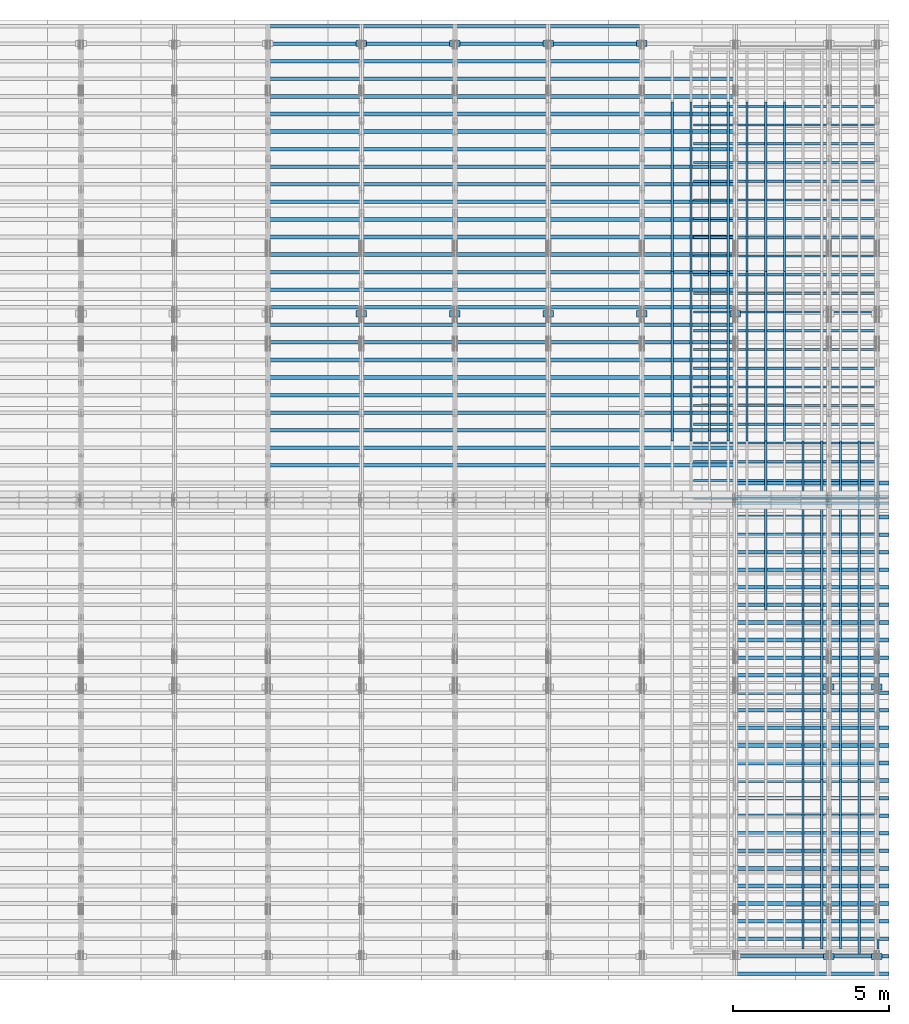
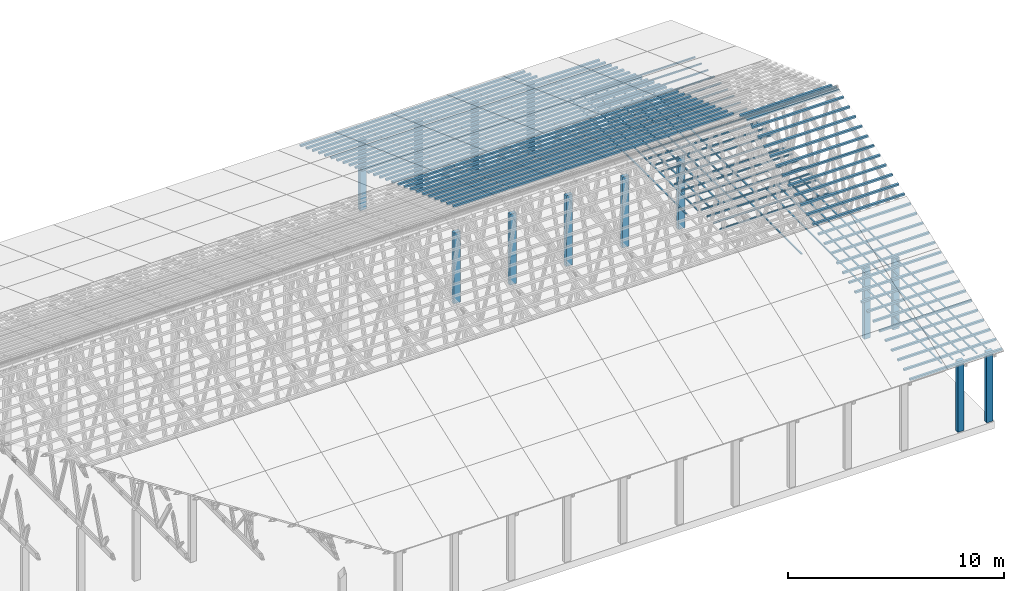
# One storey, part 4 of 189: 222 columns.
"""IFC2X3 building model written with IfcOpenShell, lengths in millimetres."""

from ifc_helpers import new_model, entity, si_unit, converted_unit, derived_unit, direction, frame, frame_2d, origin, origin_2d_with_axis, place, context, subcontext, project, spatial, rectangle, extrude, boolean, source, transform, mapped, material, type_object, type_shapes, element, save


model = new_model("IFC2X3")

# Units and contexts
model_context = context("Model", 3, precision=0.01, world=origin(), true_north=direction((6.12303176911189e-17, 1.0)))
body_context = subcontext(model_context, "Body", "Model", "MODEL_VIEW")
ifc_project = project(units=[si_unit("LENGTHUNIT", "METRE", prefix="MILLI"), si_unit("AREAUNIT", "SQUARE_METRE"), si_unit("VOLUMEUNIT", "CUBIC_METRE"), converted_unit("PLANEANGLEUNIT", "DEGREE", entity("IfcRatioMeasure", 0.0174532925199433), si_unit("PLANEANGLEUNIT", "RADIAN"), dimensions=[0, 0, 0, 0, 0, 0, 0]), si_unit("MASSUNIT", "GRAM", prefix="KILO"), derived_unit("MASSDENSITYUNIT", [(si_unit("MASSUNIT", "GRAM", prefix="KILO"), 1), (si_unit("LENGTHUNIT", "METRE"), -3)]), si_unit("TIMEUNIT", "SECOND"), si_unit("FREQUENCYUNIT", "HERTZ"), si_unit("THERMODYNAMICTEMPERATUREUNIT", "DEGREE_CELSIUS"), derived_unit("THERMALTRANSMITTANCEUNIT", [(si_unit("MASSUNIT", "GRAM", prefix="KILO"), 1), (si_unit("THERMODYNAMICTEMPERATUREUNIT", "KELVIN"), -1), (si_unit("TIMEUNIT", "SECOND"), -3)]), derived_unit("VOLUMETRICFLOWRATEUNIT", [(si_unit("LENGTHUNIT", "METRE"), 3), (si_unit("TIMEUNIT", "SECOND"), -1)]), si_unit("ELECTRICCURRENTUNIT", "AMPERE"), si_unit("ELECTRICVOLTAGEUNIT", "VOLT"), si_unit("POWERUNIT", "WATT"), si_unit("FORCEUNIT", "NEWTON"), si_unit("ILLUMINANCEUNIT", "LUX"), si_unit("LUMINOUSFLUXUNIT", "LUMEN"), si_unit("LUMINOUSINTENSITYUNIT", "CANDELA"), derived_unit("USERDEFINED", [(si_unit("MASSUNIT", "GRAM", prefix="KILO"), -1), (si_unit("LENGTHUNIT", "METRE"), -2), (si_unit("TIMEUNIT", "SECOND"), 3), (si_unit("LUMINOUSFLUXUNIT", "LUMEN"), 1)]), derived_unit("LINEARVELOCITYUNIT", [(si_unit("LENGTHUNIT", "METRE"), 1), (si_unit("TIMEUNIT", "SECOND"), -1)]), si_unit("PRESSUREUNIT", "PASCAL"), derived_unit("USERDEFINED", [(si_unit("LENGTHUNIT", "METRE"), -2), (si_unit("MASSUNIT", "GRAM", prefix="KILO"), 1), (si_unit("TIMEUNIT", "SECOND"), -2)])], contexts=[model_context])

# Site, building, storey
site_placement = place(None, origin())
site = spatial("IfcSite", under=ifc_project, at=site_placement, CompositionType="ELEMENT")
building_placement = place(site_placement, origin())
building = spatial("IfcBuilding", under=site, at=building_placement, CompositionType="ELEMENT")
storey_placement = place(building_placement, origin())
storey = spatial("IfcBuildingStorey", under=building, at=storey_placement, Name="Default", CompositionType="ELEMENT", Elevation=0.0)

# Columns
ifc_material_1 = material(Name="2")
column_type_1 = type_object("IfcColumnType", Name="100x70", PredefinedType="COLUMN")
shared_shape_1 = source(origin(), body_context, "Body", "CSG", [
    boolean("DIFFERENCE", extrude(rectangle(XDim=4925.15713546285, YDim=117.910672112436, at=frame_2d((0.0, -7.105427357601e-15), x_axis=(1.0, 0.0))), frame((2462.57856773143, 146.833369190677, -28.6286403914047)), (0.0, 0.0, 1.0), 99.9804977897746), extrude(rectangle(XDim=70.0000000018648, YDim=100.00000000027, at=frame_2d((3.5527136788005e-15, 3.5527136788005e-15), x_axis=(0.0, 1.0))), frame((4925.15713546285, 146.833369190677, 21.3616085034827), z_axis=(1.0, 0.0, 0.0), x_axis=(0.0, 0.939692620784201, -0.34202014333036)), (0.0, 0.0, -1.0), 4925.15713546285)),
])
type_shapes(column_type_1, [shared_shape_1])
for number, where, name in (
    (1, (45228.2629498526, 15149.3712807029, 5585.64342365955), "H_28_35_gradi:100x70"),
    (2, (45228.2629498526, 14712.1220107286, 5744.78914288479), "H_28_35_gradi:100x70"),
):
    element("IfcColumn", number, at=place(building_placement, frame(where)), inside=storey, type_object=column_type_1, material=ifc_material_1, Name=name, ObjectType="H_28_35_gradi:100x70", context=body_context, shape_type="MappedRepresentation", body=[
        mapped(shared_shape_1, transform((0.0, 0.0, 0.0), scale=1.0)),
    ])
column_type_2 = type_object("IfcColumnType", Name="100x70", PredefinedType="COLUMN")
shared_shape_2 = source(origin(), body_context, "Body", "CSG", [
    boolean("DIFFERENCE", extrude(rectangle(XDim=4925.15713546286, YDim=117.910672112436, at=frame_2d((0.0, 7.105427357601e-15), x_axis=(1.0, 0.0))), frame((2462.57856773143, -146.833369190677, -28.6286403914047)), (0.0, 0.0, 1.0), 99.9804977897746), extrude(rectangle(XDim=70.0000000018648, YDim=100.00000000027, at=frame_2d((3.5527136788005e-15, 3.5527136788005e-15), x_axis=(0.0, 1.0))), frame((0.0, -146.833369190677, 21.3616085034827), z_axis=(-1.0, 0.0, 0.0), x_axis=(0.0, -0.939692620784201, -0.34202014333036)), (0.0, 0.0, -1.0), 4925.15713546286)),
])
type_shapes(column_type_2, [shared_shape_2])
for number, where, name in (
    (3, (45228.2629498526, 255.239495233951, 455.341273776488), "H_28_35_gradi:100x70"),
    (4, (45228.2629498526, 819.05506770621, 660.553359769929), "H_28_35_gradi:100x70"),
    (5, (45228.2629498526, 1382.87064017775, 865.765445765329), "H_28_35_gradi:100x70"),
    (6, (45228.2629498526, 1946.6862126493, 1070.97753176073), "H_28_35_gradi:100x70"),
    (7, (45228.2629498526, 2510.50178512084, 1276.18961775613), "H_28_35_gradi:100x70"),
    (8, (45228.2629498526, 3074.31735759238, 1481.40170375153), "H_28_35_gradi:100x70"),
    (9, (45228.2629498526, 3638.13293006393, 1686.61378974693), "H_28_35_gradi:100x70"),
    (10, (45228.2629498526, 4201.94850253547, 1891.82587574233), "H_28_35_gradi:100x70"),
    (11, (45228.2629498526, 4765.76407500701, 2097.03796173773), "H_28_35_gradi:100x70"),
    (12, (45228.2629498526, 5329.57964747856, 2302.25004773314), "H_28_35_gradi:100x70"),
    (13, (45228.2629498526, 5893.3952199501, 2507.46213372854), "H_28_35_gradi:100x70"),
    (14, (45228.2629498526, 6457.21079242164, 2712.67421972394), "H_28_35_gradi:100x70"),
    (15, (45228.2629498526, 7021.02636489319, 2917.88630571934), "H_28_35_gradi:100x70"),
    (16, (45228.2629498526, 7584.84193736473, 3123.09839171474), "H_28_35_gradi:100x70"),
    (17, (45228.2629498526, 8148.65750983628, 3328.31047771014), "H_28_35_gradi:100x70"),
    (18, (45228.2629498526, 8712.47308230782, 3533.52256370554), "H_28_35_gradi:100x70"),
    (19, (45228.2629498526, 9276.28865477937, 3738.73464970094), "H_28_35_gradi:100x70"),
    (20, (45228.2629498526, 9840.10422725091, 3943.94673569634), "H_28_35_gradi:100x70"),
    (21, (45228.2629498526, 10403.9197997225, 4149.15882169174), "H_28_35_gradi:100x70"),
    (22, (45228.2629498526, 10967.735372194, 4354.37090768715), "H_28_35_gradi:100x70"),
    (23, (45228.2629498526, 11531.5509446655, 4559.58299368255), "H_28_35_gradi:100x70"),
    (24, (45228.2629498526, 12095.3665171371, 4764.79507967795), "H_28_35_gradi:100x70"),
    (25, (45228.2629498526, 12659.1820896086, 4970.00716567335), "H_28_35_gradi:100x70"),
    (26, (45228.2629498526, 13222.9976620802, 5175.21925166875), "H_28_35_gradi:100x70"),
    (27, (45228.2629498526, 13786.8132345517, 5380.43133766415), "H_28_35_gradi:100x70"),
    (28, (45228.2629498526, 14350.6288070233, 5585.64342365955), "H_28_35_gradi:100x70"),
    (29, (45228.2629498526, 14787.8780769975, 5744.78914288479), "H_28_35_gradi:100x70"),
    (30, (45228.2629498526, -308.576077237594, 250.129187781088), "H_28_35_gradi:100x70"),
):
    element("IfcColumn", number, at=place(storey_placement, frame(where)), inside=storey, type_object=column_type_2, material=ifc_material_1, Name=name, ObjectType="H_28_35_gradi:100x70", context=body_context, shape_type="MappedRepresentation", body=[
        mapped(shared_shape_2, transform((0.0, 0.0, 0.0), scale=1.0)),
    ])
column_type_3 = type_object("IfcColumnType", Name="100x70", PredefinedType="COLUMN")
shared_shape_3 = source(origin(), body_context, "Body", "CSG", [
    boolean("DIFFERENCE", extrude(rectangle(XDim=2998.26294985256, YDim=117.910672112436, at=frame_2d((0.0, -7.105427357601e-15), x_axis=(1.0, 0.0))), frame((1499.13147492628, 146.833369190677, -28.6286403914047)), (0.0, 0.0, 1.0), 99.9804977897746), extrude(rectangle(XDim=70.0000000018648, YDim=100.00000000027, at=frame_2d((3.5527136788005e-15, 3.5527136788005e-15), x_axis=(0.0, 1.0))), frame((2998.26294985256, 146.833369190677, 21.3616085034827), z_axis=(1.0, 0.0, 0.0), x_axis=(0.0, 0.939692620784201, -0.34202014333036)), (0.0, 0.0, -1.0), 2998.26294985256)),
])
type_shapes(column_type_3, [shared_shape_3])
for number, where, name in (
    (31, (42230.0, 28117.1294475484, 865.765445765329), "H_28_35_gradi:100x70"),
    (32, (42230.0, 27553.3138750769, 1070.97753176073), "H_28_35_gradi:100x70"),
    (33, (42230.0, 26989.4983026053, 1276.18961775613), "H_28_35_gradi:100x70"),
    (34, (42230.0, 26425.6827301338, 1481.40170375153), "H_28_35_gradi:100x70"),
    (35, (42230.0, 25861.8671576622, 1686.61378974693), "H_28_35_gradi:100x70"),
    (36, (42230.0, 25298.0515851907, 1891.82587574233), "H_28_35_gradi:100x70"),
    (37, (42230.0, 24734.2360127191, 2097.03796173773), "H_28_35_gradi:100x70"),
    (38, (42230.0, 24170.4204402476, 2302.25004773314), "H_28_35_gradi:100x70"),
    (39, (42230.0, 23606.6048677761, 2507.46213372854), "H_28_35_gradi:100x70"),
    (40, (42230.0, 23042.7892953045, 2712.67421972394), "H_28_35_gradi:100x70"),
    (41, (42230.0, 22478.973722833, 2917.88630571934), "H_28_35_gradi:100x70"),
    (42, (42230.0, 21915.1581503614, 3123.09839171474), "H_28_35_gradi:100x70"),
    (43, (42230.0, 21351.3425778899, 3328.31047771014), "H_28_35_gradi:100x70"),
    (44, (42230.0, 20787.5270054183, 3533.52256370554), "H_28_35_gradi:100x70"),
    (45, (42230.0, 20223.7114329468, 3738.73464970094), "H_28_35_gradi:100x70"),
    (46, (42230.0, 19659.8958604752, 3943.94673569634), "H_28_35_gradi:100x70"),
    (47, (42230.0, 19096.0802880037, 4149.15882169174), "H_28_35_gradi:100x70"),
    (48, (42230.0, 18532.2647155322, 4354.37090768715), "H_28_35_gradi:100x70"),
    (49, (42230.0, 17968.4491430606, 4559.58299368255), "H_28_35_gradi:100x70"),
    (50, (42230.0, 17404.6335705891, 4764.79507967795), "H_28_35_gradi:100x70"),
    (51, (42230.0, 16840.8179981175, 4970.00716567335), "H_28_35_gradi:100x70"),
    (52, (42230.0, 16277.002425646, 5175.21925166875), "H_28_35_gradi:100x70"),
    (53, (42230.0, 15713.1868531744, 5380.43133766415), "H_28_35_gradi:100x70"),
    (54, (39231.7370501475, 29808.5761649638, 250.129187781087), "H_28_35_gradi:100x70"),
    (55, (39231.7370501475, 29244.7605924922, 455.341273776488), "H_28_35_gradi:100x70"),
    (56, (39231.7370501475, 28680.94502002, 660.553359769929), "H_28_35_gradi:100x70"),
    (57, (39231.7370501475, 28117.1294475484, 865.765445765329), "H_28_35_gradi:100x70"),
    (58, (39231.7370501475, 27553.3138750769, 1070.97753176073), "H_28_35_gradi:100x70"),
    (59, (39231.7370501475, 26989.4983026053, 1276.18961775613), "H_28_35_gradi:100x70"),
    (60, (39231.7370501475, 26425.6827301338, 1481.40170375153), "H_28_35_gradi:100x70"),
    (61, (39231.7370501475, 25861.8671576622, 1686.61378974693), "H_28_35_gradi:100x70"),
    (62, (39231.7370501475, 25298.0515851907, 1891.82587574233), "H_28_35_gradi:100x70"),
    (63, (39231.7370501475, 24734.2360127192, 2097.03796173773), "H_28_35_gradi:100x70"),
    (64, (39231.7370501475, 24170.4204402476, 2302.25004773314), "H_28_35_gradi:100x70"),
    (65, (39231.7370501475, 23606.6048677761, 2507.46213372854), "H_28_35_gradi:100x70"),
    (66, (39231.7370501475, 23042.7892953045, 2712.67421972394), "H_28_35_gradi:100x70"),
    (67, (39231.7370501475, 22478.973722833, 2917.88630571934), "H_28_35_gradi:100x70"),
    (68, (39231.7370501475, 21915.1581503614, 3123.09839171474), "H_28_35_gradi:100x70"),
    (69, (39231.7370501475, 21351.3425778899, 3328.31047771014), "H_28_35_gradi:100x70"),
    (70, (39231.7370501475, 20787.5270054183, 3533.52256370554), "H_28_35_gradi:100x70"),
    (71, (39231.7370501475, 20223.7114329468, 3738.73464970094), "H_28_35_gradi:100x70"),
    (72, (39231.7370501475, 19659.8958604753, 3943.94673569634), "H_28_35_gradi:100x70"),
    (73, (39231.7370501475, 19096.0802880037, 4149.15882169174), "H_28_35_gradi:100x70"),
    (74, (39231.7370501475, 18532.2647155322, 4354.37090768715), "H_28_35_gradi:100x70"),
    (75, (39231.7370501475, 17968.4491430606, 4559.58299368255), "H_28_35_gradi:100x70"),
    (76, (39231.7370501475, 17404.6335705891, 4764.79507967795), "H_28_35_gradi:100x70"),
    (77, (39231.7370501475, 16840.8179981175, 4970.00716567335), "H_28_35_gradi:100x70"),
    (78, (39231.7370501475, 16277.002425646, 5175.21925166875), "H_28_35_gradi:100x70"),
    (79, (39231.7370501475, 15713.1868531744, 5380.43133766415), "H_28_35_gradi:100x70"),
    (80, (36233.4741002949, 29808.5761649638, 250.129187781087), "H_28_35_gradi:100x70"),
    (81, (36233.4741002949, 29244.7605924922, 455.341273776488), "H_28_35_gradi:100x70"),
    (82, (36233.4741002949, 28680.94502002, 660.553359769929), "H_28_35_gradi:100x70"),
    (83, (36233.4741002949, 28117.1294475484, 865.765445765329), "H_28_35_gradi:100x70"),
    (84, (36233.4741002949, 27553.3138750769, 1070.97753176073), "H_28_35_gradi:100x70"),
    (85, (36233.4741002949, 26989.4983026053, 1276.18961775613), "H_28_35_gradi:100x70"),
    (86, (36233.4741002949, 26425.6827301338, 1481.40170375153), "H_28_35_gradi:100x70"),
    (87, (36233.4741002949, 25861.8671576622, 1686.61378974693), "H_28_35_gradi:100x70"),
    (88, (36233.4741002949, 25298.0515851907, 1891.82587574233), "H_28_35_gradi:100x70"),
    (89, (36233.4741002949, 24734.2360127192, 2097.03796173773), "H_28_35_gradi:100x70"),
    (90, (36233.4741002949, 24170.4204402476, 2302.25004773314), "H_28_35_gradi:100x70"),
    (91, (36233.4741002949, 23606.6048677761, 2507.46213372854), "H_28_35_gradi:100x70"),
    (92, (36233.4741002949, 23042.7892953045, 2712.67421972394), "H_28_35_gradi:100x70"),
    (93, (36233.4741002949, 22478.973722833, 2917.88630571934), "H_28_35_gradi:100x70"),
    (94, (36233.4741002949, 21915.1581503614, 3123.09839171474), "H_28_35_gradi:100x70"),
    (95, (36233.4741002949, 21351.3425778899, 3328.31047771014), "H_28_35_gradi:100x70"),
    (96, (36233.4741002949, 20787.5270054183, 3533.52256370554), "H_28_35_gradi:100x70"),
    (97, (36233.4741002949, 20223.7114329468, 3738.73464970094), "H_28_35_gradi:100x70"),
    (98, (36233.4741002949, 19659.8958604753, 3943.94673569634), "H_28_35_gradi:100x70"),
    (99, (36233.4741002949, 19096.0802880037, 4149.15882169174), "H_28_35_gradi:100x70"),
    (100, (36233.4741002949, 18532.2647155322, 4354.37090768715), "H_28_35_gradi:100x70"),
    (101, (36233.4741002949, 17968.4491430606, 4559.58299368255), "H_28_35_gradi:100x70"),
    (102, (36233.4741002949, 17404.6335705891, 4764.79507967795), "H_28_35_gradi:100x70"),
    (103, (36233.4741002949, 16840.8179981175, 4970.00716567335), "H_28_35_gradi:100x70"),
    (104, (36233.4741002949, 16277.002425646, 5175.21925166875), "H_28_35_gradi:100x70"),
    (105, (36233.4741002949, 15713.1868531744, 5380.43133766415), "H_28_35_gradi:100x70"),
    (106, (33235.2111504423, 29808.5761649638, 250.129187781087), "H_28_35_gradi:100x70"),
    (107, (33235.2111504423, 29244.7605924922, 455.341273776488), "H_28_35_gradi:100x70"),
    (108, (33235.2111504423, 28680.94502002, 660.553359769929), "H_28_35_gradi:100x70"),
    (109, (33235.2111504423, 28117.1294475484, 865.765445765329), "H_28_35_gradi:100x70"),
    (110, (33235.2111504423, 27553.3138750769, 1070.97753176073), "H_28_35_gradi:100x70"),
    (111, (33235.2111504423, 26989.4983026053, 1276.18961775613), "H_28_35_gradi:100x70"),
    (112, (33235.2111504423, 26425.6827301338, 1481.40170375153), "H_28_35_gradi:100x70"),
    (113, (33235.2111504423, 25861.8671576623, 1686.61378974693), "H_28_35_gradi:100x70"),
    (114, (33235.2111504423, 25298.0515851907, 1891.82587574233), "H_28_35_gradi:100x70"),
    (115, (33235.2111504423, 24734.2360127192, 2097.03796173773), "H_28_35_gradi:100x70"),
    (116, (33235.2111504423, 24170.4204402476, 2302.25004773314), "H_28_35_gradi:100x70"),
    (117, (33235.2111504423, 23606.6048677761, 2507.46213372854), "H_28_35_gradi:100x70"),
    (118, (33235.2111504423, 23042.7892953045, 2712.67421972394), "H_28_35_gradi:100x70"),
    (119, (33235.2111504423, 22478.973722833, 2917.88630571934), "H_28_35_gradi:100x70"),
    (120, (33235.2111504423, 21915.1581503615, 3123.09839171474), "H_28_35_gradi:100x70"),
    (121, (33235.2111504423, 21351.3425778899, 3328.31047771014), "H_28_35_gradi:100x70"),
    (122, (33235.2111504423, 20787.5270054184, 3533.52256370554), "H_28_35_gradi:100x70"),
    (123, (33235.2111504423, 20223.7114329468, 3738.73464970094), "H_28_35_gradi:100x70"),
    (124, (33235.2111504423, 19659.8958604753, 3943.94673569634), "H_28_35_gradi:100x70"),
    (125, (33235.2111504423, 19096.0802880037, 4149.15882169174), "H_28_35_gradi:100x70"),
    (126, (33235.2111504423, 18532.2647155322, 4354.37090768715), "H_28_35_gradi:100x70"),
    (127, (33235.2111504423, 17968.4491430606, 4559.58299368255), "H_28_35_gradi:100x70"),
    (128, (33235.2111504423, 17404.6335705891, 4764.79507967795), "H_28_35_gradi:100x70"),
    (129, (33235.2111504423, 16840.8179981175, 4970.00716567335), "H_28_35_gradi:100x70"),
    (130, (33235.2111504423, 16277.002425646, 5175.21925166875), "H_28_35_gradi:100x70"),
    (131, (33235.2111504423, 15713.1868531745, 5380.43133766415), "H_28_35_gradi:100x70"),
    (132, (30236.9482005898, 29808.5761649638, 250.129187781087), "H_28_35_gradi:100x70"),
    (133, (30236.9482005898, 29244.7605924922, 455.341273776488), "H_28_35_gradi:100x70"),
    (134, (30236.9482005898, 28680.94502002, 660.553359769929), "H_28_35_gradi:100x70"),
    (135, (30236.9482005898, 28117.1294475484, 865.765445765329), "H_28_35_gradi:100x70"),
    (136, (30236.9482005898, 27553.3138750769, 1070.97753176073), "H_28_35_gradi:100x70"),
    (137, (30236.9482005898, 26989.4983026054, 1276.18961775613), "H_28_35_gradi:100x70"),
    (138, (30236.9482005898, 26425.6827301338, 1481.40170375153), "H_28_35_gradi:100x70"),
    (139, (30236.9482005898, 25861.8671576623, 1686.61378974693), "H_28_35_gradi:100x70"),
    (140, (30236.9482005898, 25298.0515851907, 1891.82587574233), "H_28_35_gradi:100x70"),
    (141, (30236.9482005898, 24734.2360127192, 2097.03796173773), "H_28_35_gradi:100x70"),
    (142, (30236.9482005898, 24170.4204402476, 2302.25004773314), "H_28_35_gradi:100x70"),
    (143, (30236.9482005898, 23606.6048677761, 2507.46213372854), "H_28_35_gradi:100x70"),
    (144, (30236.9482005898, 23042.7892953045, 2712.67421972394), "H_28_35_gradi:100x70"),
    (145, (30236.9482005898, 22478.973722833, 2917.88630571934), "H_28_35_gradi:100x70"),
    (146, (30236.9482005898, 21915.1581503615, 3123.09839171474), "H_28_35_gradi:100x70"),
    (147, (30236.9482005898, 21351.3425778899, 3328.31047771014), "H_28_35_gradi:100x70"),
    (148, (30236.9482005898, 20787.5270054184, 3533.52256370554), "H_28_35_gradi:100x70"),
    (149, (30236.9482005898, 20223.7114329468, 3738.73464970094), "H_28_35_gradi:100x70"),
    (150, (30236.9482005898, 19659.8958604753, 3943.94673569634), "H_28_35_gradi:100x70"),
    (151, (30236.9482005898, 19096.0802880037, 4149.15882169174), "H_28_35_gradi:100x70"),
    (152, (30236.9482005898, 18532.2647155322, 4354.37090768715), "H_28_35_gradi:100x70"),
    (153, (30236.9482005898, 17968.4491430606, 4559.58299368255), "H_28_35_gradi:100x70"),
    (154, (30236.9482005898, 17404.6335705891, 4764.79507967795), "H_28_35_gradi:100x70"),
    (155, (30236.9482005898, 16840.8179981176, 4970.00716567335), "H_28_35_gradi:100x70"),
    (156, (30236.9482005898, 16277.002425646, 5175.21925166875), "H_28_35_gradi:100x70"),
    (157, (30236.9482005898, 15713.1868531745, 5380.43133766415), "H_28_35_gradi:100x70"),
):
    element("IfcColumn", number, at=place(storey_placement, frame(where)), inside=storey, type_object=column_type_3, material=ifc_material_1, Name=name, ObjectType="H_28_35_gradi:100x70", context=body_context, shape_type="MappedRepresentation", body=[
        mapped(shared_shape_3, transform((0.0, 0.0, 0.0), scale=1.0)),
    ])
column_type_4 = type_object("IfcColumnType", Name="45x70", PredefinedType="COLUMN")
shared_shape_4 = source(origin(), body_context, "Body", "SweptSolid", [
    extrude(rectangle(XDim=70.0000000000007, YDim=5950.0, at=frame_2d((1.66977542903624e-13, 0.0), x_axis=(1.0, 0.0))), frame((2975.0, 237.823014276398, 0.0), z_axis=(0.0, 0.0, 1.0), x_axis=(0.0, -1.0, 0.0)), (0.0, 0.0, 1.0), 44.9999999999788),
])
type_shapes(column_type_4, [shared_shape_4])
for number, where, z_axis, x_axis, name in (
    (158, (49837.7477027694, 15017.8230142764, -45.0), (0.0, 0.0, 1.0), (-1.0, 0.0, 0.0), "H:45x70"),
    (159, (49837.7477027694, 15617.8230142764, -45.0), (0.0, 0.0, 1.0), (-1.0, 0.0, 0.0), "H:45x70"),
    (160, (49837.7477027694, 16217.8230142764, -45.0), (0.0, 0.0, 1.0), (-1.0, 0.0, 0.0), "H:45x70"),
    (161, (49837.7477027694, 16817.8230142764, -45.0), (0.0, 0.0, 1.0), (-1.0, 0.0, 0.0), "H:45x70"),
    (162, (49837.7477027694, 17417.8230142764, -45.0), (0.0, 0.0, 1.0), (-1.0, 0.0, 0.0), "H:45x70"),
    (163, (49837.7477027694, 18017.8230142764, -45.0), (0.0, 0.0, 1.0), (-1.0, 0.0, 0.0), "H:45x70"),
    (164, (49837.7477027694, 18617.8230142764, -45.0), (0.0, 0.0, 1.0), (-1.0, 0.0, 0.0), "H:45x70"),
    (165, (49837.7477027694, 19217.8230142764, -45.0), (0.0, 0.0, 1.0), (-1.0, 0.0, 0.0), "H:45x70"),
    (166, (49837.7477027694, 19817.8230142764, -45.0), (0.0, 0.0, 1.0), (-1.0, 0.0, 0.0), "H:45x70"),
    (167, (49837.7477027694, 20417.8230142764, -45.0), (0.0, 0.0, 1.0), (-1.0, 0.0, 0.0), "H:45x70"),
    (168, (49837.7477027694, 21017.8230142764, -45.0), (0.0, 0.0, 1.0), (-1.0, 0.0, 0.0), "H:45x70"),
    (169, (49837.7477027694, 21617.8230142764, -45.0), (0.0, 0.0, 1.0), (-1.0, 0.0, 0.0), "H:45x70"),
    (170, (49837.7477027694, 22217.8230142764, -45.0), (0.0, 0.0, 1.0), (-1.0, 0.0, 0.0), "H:45x70"),
    (171, (49837.7477027694, 22817.8230142764, -45.0), (0.0, 0.0, 1.0), (-1.0, 0.0, 0.0), "H:45x70"),
    (172, (49837.7477027694, 23417.8230142764, -45.0), (0.0, 0.0, 1.0), (-1.0, 0.0, 0.0), "H:45x70"),
    (173, (49837.7477027694, 24017.8230142764, -45.0), (0.0, 0.0, 1.0), (-1.0, 0.0, 0.0), "H:45x70"),
    (174, (49837.7477027694, 24617.8230142764, -45.0), (0.0, 0.0, 1.0), (-1.0, 0.0, 0.0), "H:45x70"),
    (175, (49837.7477027694, 25217.8230142764, -45.0), (0.0, 0.0, 1.0), (-1.0, 0.0, 0.0), "H:45x70"),
    (176, (49837.7477027694, 25817.8230142764, -45.0), (0.0, 0.0, 1.0), (-1.0, 0.0, 0.0), "H:45x70"),
    (177, (49837.7477027694, 26417.8230142764, -45.0), (0.0, 0.0, 1.0), (-1.0, 0.0, 0.0), "H:45x70"),
    (178, (49837.7477027694, 27017.8230142764, -45.0), (0.0, 0.0, 1.0), (-1.0, 0.0, 0.0), "H:45x70"),
    (179, (49837.7477027694, 27617.8230142764, -45.0), (0.0, 0.0, 1.0), (-1.0, 0.0, 0.0), "H:45x70"),
):
    element("IfcColumn", number, at=place(storey_placement, frame(where, z_axis=z_axis, x_axis=x_axis)), inside=storey, type_object=column_type_4, material=ifc_material_1, Name=name, ObjectType="H:45x70", context=body_context, shape_type="MappedRepresentation", body=[
        mapped(shared_shape_4, transform((0.0, 0.0, 0.0), scale=1.0)),
    ])
column_type_5 = type_object("IfcColumnType", Name="45x70", PredefinedType="COLUMN")
shared_shape_5 = source(origin(), body_context, "Body", "SweptSolid", [
    extrude(rectangle(XDim=70.0000000000007, YDim=5434.29684744924, at=frame_2d((1.66977542903624e-13, 0.0), x_axis=(1.0, 0.0))), frame((2717.14842372462, 237.823014276398, 0.0), z_axis=(0.0, 0.0, 1.0), x_axis=(0.0, -1.0, 0.0)), (0.0, 0.0, 1.0), 44.9999999999788),
])
type_shapes(column_type_5, [shared_shape_5])
for number, where, z_axis, x_axis, name in (
    (180, (50040.5707170458, 345.0, -90.0), (0.0, 0.0, 1.0), (0.0, 1.0, 0.0), "H:45x70"),
    (181, (50040.5707170458, 5779.29684744924, -90.0), (0.0, 0.0, 1.0), (0.0, 1.0, 0.0), "H:45x70"),
    (182, (49440.5707170458, 5779.29684744924, -90.0), (0.0, 0.0, 1.0), (0.0, 1.0, 0.0), "H:45x70"),
    (183, (50040.5707170458, 11213.5936948985, -90.0), (0.0, 0.0, 1.0), (0.0, 1.0, 0.0), "H:45x70"),
    (184, (49440.5707170458, 11213.5936948985, -90.0), (0.0, 0.0, 1.0), (0.0, 1.0, 0.0), "H:45x70"),
    (185, (48840.5707170458, 345.0, -90.0), (0.0, 0.0, 1.0), (0.0, 1.0, 0.0), "H:45x70"),
    (186, (48840.5707170458, 5779.29684744924, -90.0), (0.0, 0.0, 1.0), (0.0, 1.0, 0.0), "H:45x70"),
    (187, (48840.5707170458, 11213.5936948985, -90.0), (0.0, 0.0, 1.0), (0.0, 1.0, 0.0), "H:45x70"),
    (188, (48240.5707170458, 345.0, -90.0), (0.0, 0.0, 1.0), (0.0, 1.0, 0.0), "H:45x70"),
    (189, (48240.5707170458, 5779.29684744924, -90.0), (0.0, 0.0, 1.0), (0.0, 1.0, 0.0), "H:45x70"),
    (190, (48240.5707170458, 11213.5936948985, -90.0), (0.0, 0.0, 1.0), (0.0, 1.0, 0.0), "H:45x70"),
    (191, (47640.5707170458, 345.0, -90.0), (0.0, 0.0, 1.0), (0.0, 1.0, 0.0), "H:45x70"),
    (192, (47640.5707170458, 5779.29684744924, -90.0), (0.0, 0.0, 1.0), (0.0, 1.0, 0.0), "H:45x70"),
    (193, (47640.5707170458, 11213.5936948985, -90.0), (0.0, 0.0, 1.0), (0.0, 1.0, 0.0), "H:45x70"),
    (194, (47040.5707170458, 16647.8905423477, -90.0), (0.0, 0.0, 1.0), (0.0, 1.0, 0.0), "H:45x70"),
    (195, (47040.5707170459, 22082.187389797, -90.0), (0.0, 0.0, 1.0), (0.0, 1.0, 0.0), "H:45x70"),
    (196, (46440.5707170458, 11213.5936948985, -90.0), (0.0, 0.0, 1.0), (0.0, 1.0, 0.0), "H:45x70"),
    (197, (46440.5707170458, 16647.8905423477, -90.0), (0.0, 0.0, 1.0), (0.0, 1.0, 0.0), "H:45x70"),
    (198, (46440.5707170459, 22082.187389797, -90.0), (0.0, 0.0, 1.0), (0.0, 1.0, 0.0), "H:45x70"),
    (199, (45840.5707170458, 16647.8905423477, -90.0), (0.0, 0.0, 1.0), (0.0, 1.0, 0.0), "H:45x70"),
    (200, (45840.5707170458, 22082.187389797, -90.0), (0.0, 0.0, 1.0), (0.0, 1.0, 0.0), "H:45x70"),
    (201, (45240.5707170458, 16647.8905423477, -90.0), (0.0, 0.0, 1.0), (0.0, 1.0, 0.0), "H:45x70"),
    (202, (45240.5707170458, 22082.187389797, -90.0), (0.0, 0.0, 1.0), (0.0, 1.0, 0.0), "H:45x70"),
    (203, (44640.5707170458, 16647.8905423477, -90.0), (0.0, 0.0, 1.0), (0.0, 1.0, 0.0), "H:45x70"),
    (204, (44640.5707170458, 22082.187389797, -90.0), (0.0, 0.0, 1.0), (0.0, 1.0, 0.0), "H:45x70"),
    (205, (44040.5707170458, 16647.8905423477, -90.0), (0.0, 0.0, 1.0), (0.0, 1.0, 0.0), "H:45x70"),
    (206, (44040.5707170458, 22082.187389797, -90.0), (0.0, 0.0, 1.0), (0.0, 1.0, 0.0), "H:45x70"),
    (207, (43440.5707170458, 16647.8905423477, -90.0), (0.0, 0.0, 1.0), (0.0, 1.0, 0.0), "H:45x70"),
    (208, (43440.5707170458, 22082.187389797, -90.0), (0.0, 0.0, 1.0), (0.0, 1.0, 0.0), "H:45x70"),
):
    element("IfcColumn", number, at=place(storey_placement, frame(where, z_axis=z_axis, x_axis=x_axis)), inside=storey, type_object=column_type_5, material=ifc_material_1, Name=name, ObjectType="H:45x70", context=body_context, shape_type="MappedRepresentation", body=[
        mapped(shared_shape_5, transform((0.0, 0.0, 0.0), scale=1.0)),
    ])
column_type_6 = type_object("IfcColumnType", Name="45x70", PredefinedType="COLUMN")
shared_shape_6 = source(origin(), body_context, "Body", "SweptSolid", [
    extrude(rectangle(XDim=70.0000000000007, YDim=5574.29684744923, at=frame_2d((1.66977542903624e-13, 0.0), x_axis=(1.0, 0.0))), frame((2787.14842372461, 237.823014276398, 0.0), z_axis=(0.0, 0.0, 1.0), x_axis=(0.0, -1.0, 0.0)), (0.0, 0.0, 1.0), 44.9999999999788),
])
type_shapes(column_type_6, [shared_shape_6])
column_1_placement = place(storey_placement, frame((49440.5707170458, 205.0, -90.0), z_axis=(0.0, 0.0, 1.0), x_axis=(0.0, 1.0, 0.0)))
element("IfcColumn", 209, at=column_1_placement, inside=storey, type_object=column_type_6, material=ifc_material_1, Name="H:45x70", ObjectType="H:45x70", context=body_context, shape_type="MappedRepresentation", body=[
    mapped(shared_shape_6, transform((0.0, 0.0, 0.0), scale=1.0)),
])
ifc_material_2 = material()
column_type_7 = type_object("IfcColumnType", Name="200x200", PredefinedType="COLUMN")
shared_shape_7 = source(origin(), body_context, "Body", "SweptSolid", [
    extrude(rectangle(XDim=339.999999999998, YDim=200.000000000004, at=origin_2d_with_axis()), frame((100.0, 280.0, -4000.0), z_axis=(0.0, 0.0, 1.0), x_axis=(0.0, -1.0, 0.0)), (0.0, 0.0, 1.0), 4000.0),
])
type_shapes(column_type_7, [shared_shape_7])
column_2_placement = place(building_placement, frame((50050.0, 0.0, 0.0), z_axis=(0.0, 0.0, 1.0), x_axis=(0.0, 1.0, 0.0)))
element("IfcColumn", 210, at=column_2_placement, inside=storey, type_object=column_type_7, material=ifc_material_2, Name="V:200x200", ObjectType="V:200x200", context=body_context, shape_type="MappedRepresentation", body=[
    mapped(shared_shape_7, transform((0.0, 0.0, 0.0), scale=1.0)),
])
column_type_8 = type_object("IfcColumnType", Name="200x200", PredefinedType="COLUMN")
shared_shape_8 = source(origin(), body_context, "Body", "SweptSolid", [
    extrude(rectangle(XDim=339.999999999998, YDim=200.000000000004, at=origin_2d_with_axis()), frame((100.0, 280.0, -4000.0), z_axis=(0.0, 0.0, 1.0), x_axis=(0.0, -1.0, 0.0)), (0.0, 0.0, 1.0), 4000.0),
])
type_shapes(column_type_8, [shared_shape_8])
for number, where, z_axis, x_axis, name in (
    (211, (48510.0, 0.0, 0.0), (0.0, 0.0, 1.0), (0.0, 1.0, 0.0), "V:200x200"),
    (212, (50050.0, 8650.0, 0.0), (0.0, 0.0, 1.0), (0.0, 1.0, 0.0), "V:200x200"),
    (213, (48510.0, 8650.0, 0.0), (0.0, 0.0, 1.0), (0.0, 1.0, 0.0), "V:200x200"),
    (214, (45510.0, 20629.6217832149, 0.0), (0.0, 0.0, 1.0), (0.0, 1.0, 0.0), "V:200x200"),
    (215, (42510.0, 20629.6217832149, 0.0), (0.0, 0.0, 1.0), (0.0, 1.0, 0.0), "V:200x200"),
    (216, (39510.0, 20629.6217832149, 0.0), (0.0, 0.0, 1.0), (0.0, 1.0, 0.0), "V:200x200"),
    (217, (36510.0, 20629.6217832149, 0.0), (0.0, 0.0, 1.0), (0.0, 1.0, 0.0), "V:200x200"),
    (218, (33510.0, 20629.6217832149, 0.0), (0.0, 0.0, 1.0), (0.0, 1.0, 0.0), "V:200x200"),
    (219, (42510.0, 29300.0, 0.0), (0.0, 0.0, 1.0), (0.0, 1.0, 0.0), "V:200x200"),
    (220, (39510.0, 29300.0, 0.0), (0.0, 0.0, 1.0), (0.0, 1.0, 0.0), "V:200x200"),
    (221, (36510.0, 29300.0, 0.0), (0.0, 0.0, 1.0), (0.0, 1.0, 0.0), "V:200x200"),
    (222, (33510.0, 29300.0, 0.0), (0.0, 0.0, 1.0), (0.0, 1.0, 0.0), "V:200x200"),
):
    element("IfcColumn", number, at=place(storey_placement, frame(where, z_axis=z_axis, x_axis=x_axis)), inside=storey, type_object=column_type_8, material=ifc_material_2, Name=name, ObjectType="V:200x200", context=body_context, shape_type="MappedRepresentation", body=[
        mapped(shared_shape_8, transform((0.0, 0.0, 0.0), scale=1.0)),
    ])

save(model, "model.ifc")
